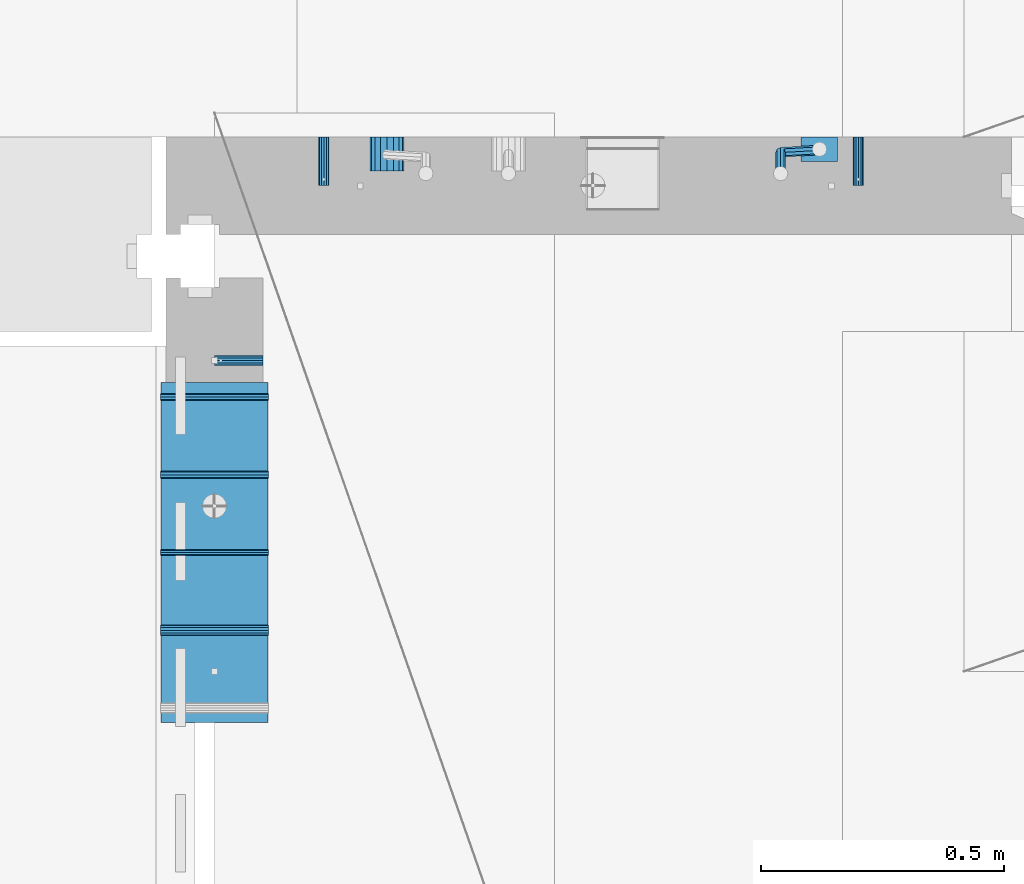
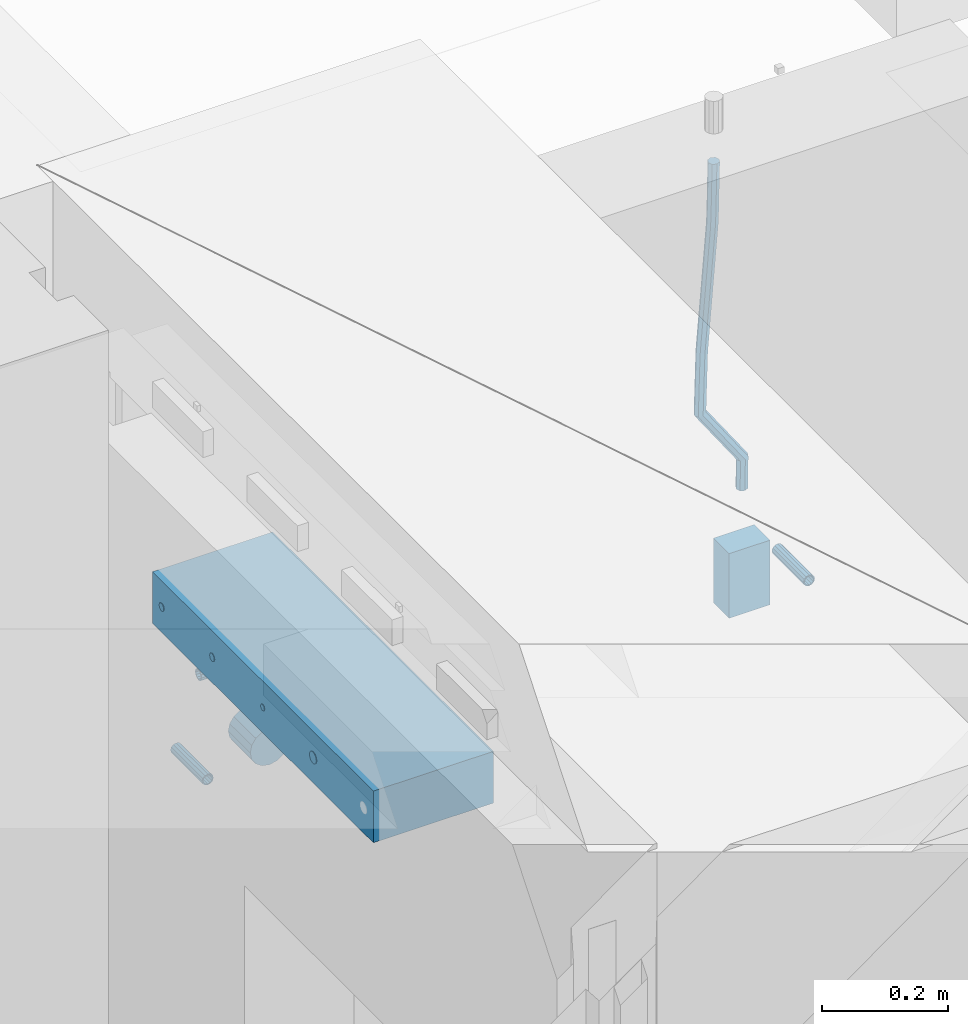
# One storey, part 164 of 350: 11 beams, 5 elements without a shape of their own.
"""IFC2X3 building model written with IfcOpenShell, lengths in millimetres."""

from ifc_helpers import new_model, si_unit, frame, origin_with_axes, place, context, subcontext, project, spatial, faceted_brep, material, type_object, element, aggregate, save


model = new_model("IFC2X3")

# Units and contexts
model_context = context("Model", 3, precision=1e-05, world=origin_with_axes())
body_context = subcontext(model_context, "Body", "Model", "MODEL_VIEW")
ifc_project = project(units=[si_unit("LENGTHUNIT", "METRE", prefix="MILLI"), si_unit("AREAUNIT", "SQUARE_METRE"), si_unit("VOLUMEUNIT", "CUBIC_METRE"), si_unit("MASSUNIT", "GRAM", prefix="KILO"), si_unit("TIMEUNIT", "SECOND"), si_unit("PLANEANGLEUNIT", "RADIAN"), si_unit("SOLIDANGLEUNIT", "STERADIAN"), si_unit("THERMODYNAMICTEMPERATUREUNIT", "DEGREE_CELSIUS"), si_unit("LUMINOUSINTENSITYUNIT", "LUMEN")], contexts=[model_context])

# Site, building, storey
site_placement = place(None, origin_with_axes())
site = spatial("IfcSite", under=ifc_project, at=site_placement, CompositionType="ELEMENT")
building_placement = place(site_placement, origin_with_axes())
building = spatial("IfcBuilding", under=site, at=building_placement, CompositionType="ELEMENT")
storey_placement = place(building_placement, origin_with_axes())
storey = spatial("IfcBuildingStorey", under=building, at=storey_placement, Name="2", CompositionType="ELEMENT", Elevation=0.0)

# Assemblies, beam
assembly_1_placement = place(storey_placement, origin_with_axes())
assembly_1 = element("IfcElementAssembly", 1, at=assembly_1_placement, inside=storey, AssemblyPlace="NOTDEFINED", PredefinedType="REINFORCEMENT_UNIT")
assembly_2_placement = place(assembly_1_placement, origin_with_axes())
assembly_2 = element("IfcElementAssembly", 2, at=assembly_2_placement, Name="Steel Assembly", AssemblyPlace="NOTDEFINED", PredefinedType="RIGID_FRAME")
ifc_material_1 = material(Name="STEEL/Steel_Undefined")
beam_type_1 = type_object("IfcBeamType", PredefinedType="NOTDEFINED")
beam_1_placement = place(assembly_2_placement, frame((26709.9991475894, 16620.0032612672, 87055.0), z_axis=(0.0, 1.0, 0.0), x_axis=(-1.0, 3.00000001838171e-08, 0.0)))
beam_1 = element("IfcBeam", 3, at=beam_1_placement, type_object=beam_type_1, material=ifc_material_1, Name="M16", context=body_context, shape_type="Brep", body=[
    faceted_brep([(0.0, -8.49999999999272, -1.45519152283669e-11), (0.0, -7.36121593215648, 4.24999999998545), (100.000000000262, -7.36121593215648, 4.24999999998545), (100.000000000262, -8.49999999999272, -1.45519152283669e-11), (0.0, -4.24999999998545, 7.36121593216376), (100.000000000262, -4.24999999998545, 7.36121593216376), (0.0, 1.45519152283669e-11, 8.49999999998545), (100.000000000262, 1.45519152283669e-11, 8.49999999998545), (0.0, 4.25000000001455, 7.36121593216376), (100.000000000262, 4.25000000001455, 7.36121593216376), (0.0, 7.36121593217104, 4.24999999998545), (100.000000000262, 7.36121593217104, 4.24999999998545), (0.0, 8.50000000000728, 0.0), (100.000000000262, 8.50000000000728, 0.0), (0.0, 7.36121593217104, -4.25000000001455), (100.000000000262, 7.36121593217104, -4.25000000001455), (0.0, 4.25000000000728, -7.36121593219286), (100.000000000262, 4.25000000000728, -7.36121593219286), (0.0, 7.27595761418343e-12, -8.5), (100.000000000262, 7.27595761418343e-12, -8.5), (0.0, -4.24999999999272, -7.36121593217831), (100.000000000262, -4.24999999999272, -7.36121593217831), (0.0, -7.36121593215648, -4.25), (100.000000000262, -7.36121593215648, -4.25), (0.0, -10.4999999999927, -1.45519152283669e-11), (0.0, -9.09326673972828, -5.25000000001455), (100.000000000262, -9.09326673972828, -5.25000000001455), (100.000000000262, -10.4999999999927, -1.45519152283669e-11), (0.0, -5.24999999998545, -9.09326673974283), (100.000000000262, -5.24999999998545, -9.09326673974283), (0.0, 7.27595761418343e-12, -10.5), (100.000000000262, 7.27595761418343e-12, -10.5), (0.0, 5.25000000001455, -9.09326673975738), (100.000000000262, 5.25000000001455, -9.09326673975738), (0.0, 9.09326673975011, -5.25000000001455), (100.000000000262, 9.09326673975011, -5.25000000001455), (0.0, 10.5000000000073, -1.45519152283669e-11), (100.000000000262, 10.5000000000073, -1.45519152283669e-11), (0.0, 9.09326673975011, 5.25), (100.000000000262, 9.09326673975011, 5.25), (0.0, 5.25000000000728, 9.09326673972828), (100.000000000262, 5.25000000000728, 9.09326673972828), (0.0, 1.45519152283669e-11, 10.4999999999854), (100.000000000262, 1.45519152283669e-11, 10.4999999999854), (0.0, -5.24999999999272, 9.09326673972828), (100.000000000262, -5.24999999999272, 9.09326673972828), (0.0, -9.09326673972828, 5.24999999998545), (100.000000000262, -9.09326673972828, 5.24999999998545)], [[[0, 1, 2, 3]], [[1, 4, 5, 2]], [[4, 6, 7, 5]], [[6, 8, 9, 7]], [[8, 10, 11, 9]], [[10, 12, 13, 11]], [[12, 14, 15, 13]], [[14, 16, 17, 15]], [[16, 18, 19, 17]], [[18, 20, 21, 19]], [[20, 22, 23, 21]], [[22, 0, 3, 23]], [[24, 25, 26, 27]], [[25, 28, 29, 26]], [[28, 30, 31, 29]], [[30, 32, 33, 31]], [[32, 34, 35, 33]], [[34, 36, 37, 35]], [[36, 38, 39, 37]], [[38, 40, 41, 39]], [[40, 42, 43, 41]], [[42, 44, 45, 43]], [[44, 46, 47, 45]], [[46, 24, 27, 47]], [[29, 31, 33, 35, 37, 39, 41, 43, 45, 47, 27, 26], [5, 7, 9, 11, 13, 15, 17, 19, 21, 23, 3, 2]], [[46, 44, 42, 40, 38, 36, 34, 32, 30, 28, 25, 24], [22, 20, 18, 16, 14, 12, 10, 8, 6, 4, 1, 0]]]),
])
aggregate(assembly_2, [beam_1])

# Assemblies, beams
assembly_3_placement = place(storey_placement, origin_with_axes())
assembly_3 = element("IfcElementAssembly", 4, at=assembly_3_placement, inside=storey, AssemblyPlace="NOTDEFINED", PredefinedType="REINFORCEMENT_UNIT")
assembly_4_placement = place(assembly_3_placement, origin_with_axes())
assembly_4 = element("IfcElementAssembly", 5, at=assembly_4_placement, Name="Steel Assembly", AssemblyPlace="NOTDEFINED", PredefinedType="RIGID_FRAME")
beam_2_placement = place(assembly_4_placement, frame((27934.9999668009, 17080.0, 86555.0), z_axis=(1.0, 0.0, 0.0), x_axis=(0.0, -1.0, 0.0)))
beam_2 = element("IfcBeam", 6, at=beam_2_placement, type_object=beam_type_1, material=ifc_material_1, Name="M16", context=body_context, shape_type="Brep", body=[
    faceted_brep([(0.0, -8.49999999999272, -1.45519152283669e-11), (0.0, -7.36121593215648, 4.24999999998545), (100.000000000262, -7.36121593215648, 4.24999999998545), (100.000000000262, -8.49999999999272, -1.45519152283669e-11), (0.0, -4.24999999998545, 7.36121593216376), (100.000000000262, -4.24999999998545, 7.36121593216376), (0.0, 1.45519152283669e-11, 8.49999999998545), (100.000000000262, 1.45519152283669e-11, 8.49999999998545), (0.0, 4.25000000001455, 7.36121593216376), (100.000000000262, 4.25000000001455, 7.36121593216376), (0.0, 7.36121593217104, 4.24999999998545), (100.000000000262, 7.36121593217104, 4.24999999998545), (0.0, 8.50000000000728, 0.0), (100.000000000262, 8.50000000000728, 0.0), (0.0, 7.36121593217104, -4.25000000001455), (100.000000000262, 7.36121593217104, -4.25000000001455), (0.0, 4.25000000000728, -7.36121593219286), (100.000000000262, 4.25000000000728, -7.36121593219286), (0.0, 7.27595761418343e-12, -8.5), (100.000000000262, 7.27595761418343e-12, -8.5), (0.0, -4.24999999999272, -7.36121593217831), (100.000000000262, -4.24999999999272, -7.36121593217831), (0.0, -7.36121593215648, -4.25), (100.000000000262, -7.36121593215648, -4.25), (0.0, -10.4999999999927, -1.45519152283669e-11), (0.0, -9.09326673972828, -5.25000000001455), (100.000000000262, -9.09326673972828, -5.25000000001455), (100.000000000262, -10.4999999999927, -1.45519152283669e-11), (0.0, -5.24999999998545, -9.09326673974283), (100.000000000262, -5.24999999998545, -9.09326673974283), (0.0, 7.27595761418343e-12, -10.5), (100.000000000262, 7.27595761418343e-12, -10.5), (0.0, 5.25000000001455, -9.09326673975738), (100.000000000262, 5.25000000001455, -9.09326673975738), (0.0, 9.09326673975011, -5.25000000001455), (100.000000000262, 9.09326673975011, -5.25000000001455), (0.0, 10.5000000000073, -1.45519152283669e-11), (100.000000000262, 10.5000000000073, -1.45519152283669e-11), (0.0, 9.09326673975011, 5.25), (100.000000000262, 9.09326673975011, 5.25), (0.0, 5.25000000000728, 9.09326673972828), (100.000000000262, 5.25000000000728, 9.09326673972828), (0.0, 1.45519152283669e-11, 10.4999999999854), (100.000000000262, 1.45519152283669e-11, 10.4999999999854), (0.0, -5.24999999999272, 9.09326673972828), (100.000000000262, -5.24999999999272, 9.09326673972828), (0.0, -9.09326673972828, 5.24999999998545), (100.000000000262, -9.09326673972828, 5.24999999998545)], [[[0, 1, 2, 3]], [[1, 4, 5, 2]], [[4, 6, 7, 5]], [[6, 8, 9, 7]], [[8, 10, 11, 9]], [[10, 12, 13, 11]], [[12, 14, 15, 13]], [[14, 16, 17, 15]], [[16, 18, 19, 17]], [[18, 20, 21, 19]], [[20, 22, 23, 21]], [[22, 0, 3, 23]], [[24, 25, 26, 27]], [[25, 28, 29, 26]], [[28, 30, 31, 29]], [[30, 32, 33, 31]], [[32, 34, 35, 33]], [[34, 36, 37, 35]], [[36, 38, 39, 37]], [[38, 40, 41, 39]], [[40, 42, 43, 41]], [[42, 44, 45, 43]], [[44, 46, 47, 45]], [[46, 24, 27, 47]], [[29, 31, 33, 35, 37, 39, 41, 43, 45, 47, 27, 26], [5, 7, 9, 11, 13, 15, 17, 19, 21, 23, 3, 2]], [[46, 44, 42, 40, 38, 36, 34, 32, 30, 28, 25, 24], [22, 20, 18, 16, 14, 12, 10, 8, 6, 4, 1, 0]]]),
])
aggregate(assembly_4, [beam_2])
assembly_5_placement = place(assembly_3_placement, origin_with_axes())
assembly_5 = element("IfcElementAssembly", 7, at=assembly_5_placement, Name="Steel Assembly", AssemblyPlace="NOTDEFINED", PredefinedType="RIGID_FRAME")
beam_3_placement = place(assembly_5_placement, frame((26834.9999668009, 17080.0, 86555.0), z_axis=(-1.0, 3.00000001838171e-08, 0.0), x_axis=(0.0, -1.0, 0.0)))
beam_3 = element("IfcBeam", 8, at=beam_3_placement, type_object=beam_type_1, material=ifc_material_1, Name="M16", context=body_context, shape_type="Brep", body=[
    faceted_brep([(0.0, -8.49999999999272, -1.45519152283669e-11), (0.0, -7.36121593215648, 4.24999999998545), (100.000000000262, -7.36121593215648, 4.24999999998545), (100.000000000262, -8.49999999999272, -1.45519152283669e-11), (0.0, -4.24999999998545, 7.36121593216376), (100.000000000262, -4.24999999998545, 7.36121593216376), (0.0, 1.45519152283669e-11, 8.49999999998545), (100.000000000262, 1.45519152283669e-11, 8.49999999998545), (0.0, 4.25000000001455, 7.36121593216376), (100.000000000262, 4.25000000001455, 7.36121593216376), (0.0, 7.36121593217104, 4.24999999998545), (100.000000000262, 7.36121593217104, 4.24999999998545), (0.0, 8.50000000000728, 0.0), (100.000000000262, 8.50000000000728, 0.0), (0.0, 7.36121593217104, -4.25000000001455), (100.000000000262, 7.36121593217104, -4.25000000001455), (0.0, 4.25000000000728, -7.36121593219286), (100.000000000262, 4.25000000000728, -7.36121593219286), (0.0, 7.27595761418343e-12, -8.5), (100.000000000262, 7.27595761418343e-12, -8.5), (0.0, -4.24999999999272, -7.36121593217831), (100.000000000262, -4.24999999999272, -7.36121593217831), (0.0, -7.36121593215648, -4.25), (100.000000000262, -7.36121593215648, -4.25), (0.0, -10.4999999999927, -1.45519152283669e-11), (0.0, -9.09326673972828, -5.25000000001455), (100.000000000262, -9.09326673972828, -5.25000000001455), (100.000000000262, -10.4999999999927, -1.45519152283669e-11), (0.0, -5.24999999998545, -9.09326673974283), (100.000000000262, -5.24999999998545, -9.09326673974283), (0.0, 7.27595761418343e-12, -10.5), (100.000000000262, 7.27595761418343e-12, -10.5), (0.0, 5.25000000001455, -9.09326673975738), (100.000000000262, 5.25000000001455, -9.09326673975738), (0.0, 9.09326673975011, -5.25000000001455), (100.000000000262, 9.09326673975011, -5.25000000001455), (0.0, 10.5000000000073, -1.45519152283669e-11), (100.000000000262, 10.5000000000073, -1.45519152283669e-11), (0.0, 9.09326673975011, 5.25), (100.000000000262, 9.09326673975011, 5.25), (0.0, 5.25000000000728, 9.09326673972828), (100.000000000262, 5.25000000000728, 9.09326673972828), (0.0, 1.45519152283669e-11, 10.4999999999854), (100.000000000262, 1.45519152283669e-11, 10.4999999999854), (0.0, -5.24999999999272, 9.09326673972828), (100.000000000262, -5.24999999999272, 9.09326673972828), (0.0, -9.09326673972828, 5.24999999998545), (100.000000000262, -9.09326673972828, 5.24999999998545)], [[[0, 1, 2, 3]], [[1, 4, 5, 2]], [[4, 6, 7, 5]], [[6, 8, 9, 7]], [[8, 10, 11, 9]], [[10, 12, 13, 11]], [[12, 14, 15, 13]], [[14, 16, 17, 15]], [[16, 18, 19, 17]], [[18, 20, 21, 19]], [[20, 22, 23, 21]], [[22, 0, 3, 23]], [[24, 25, 26, 27]], [[25, 28, 29, 26]], [[28, 30, 31, 29]], [[30, 32, 33, 31]], [[32, 34, 35, 33]], [[34, 36, 37, 35]], [[36, 38, 39, 37]], [[38, 40, 41, 39]], [[40, 42, 43, 41]], [[42, 44, 45, 43]], [[44, 46, 47, 45]], [[46, 24, 27, 47]], [[29, 31, 33, 35, 37, 39, 41, 43, 45, 47, 27, 26], [5, 7, 9, 11, 13, 15, 17, 19, 21, 23, 3, 2]], [[46, 44, 42, 40, 38, 36, 34, 32, 30, 28, 25, 24], [22, 20, 18, 16, 14, 12, 10, 8, 6, 4, 1, 0]]]),
])
aggregate(assembly_5, [beam_3])
ifc_material_2 = material()
beam_type_2 = type_object("IfcBeamType", Name="D20", PredefinedType="NOTDEFINED")
beam_4_placement = place(assembly_3_placement, frame((27854.9999105249, 17055.0000022791, 86717.5), z_axis=(0.00020576299992186, -0.999642804629538, -0.0267249099901004), x_axis=(-4.30000201928125e-08, -0.0267249099948059, 0.999642825806181)))
beam_4 = element("IfcBeam", 9, at=beam_4_placement, type_object=beam_type_2, material=ifc_material_2, Name="JM20", ObjectType="D20", context=body_context, shape_type="Brep", body=[
    faceted_brep([(0.0, -10.0, 0.0), (-4.19531716033816e-08, -7.07106781186667, -7.07106781187031), (57.3778003524785, -7.07106779628884, -7.0710678060168), (57.3778003565822, -9.99999998442945, 5.84986992180347e-09), (0.0, 0.0, -10.0), (57.3778003491898, 1.55741872731596e-08, -9.99999999415013), (4.196772351861e-08, 7.07106781186303, -7.07106781186667), (57.3778003486368, 7.07106782744086, -7.0710678060168), (0.0, 10.0, 0.0), (57.3778003511543, 10.0000000155705, 5.84986992180347e-09), (4.196772351861e-08, 7.07106781185939, 7.07106781185939), (57.3778003552725, 7.07106782744086, 7.0710678177129), (0.0, 0.0, 10.0), (57.3778003585467, 1.55741872731596e-08, 10.0000000058535), (-4.19531716033816e-08, -7.07106781187031, 7.07106781185939), (57.3778003591142, -7.07106779628884, 7.0710678177129), (63.2348501311644, -7.07106779493188, -7.07106780540926), (64.1057957623998, -9.99999998283238, 6.54472387395799e-09), (61.04994790192, 1.63490767590702e-08, -9.99999999377178), (58.8309751681372, 7.07106782761548, -7.07106780586037), (57.8777760627127, 10.0000000155014, 5.90807758271694e-09), (58.7487216939626, 7.07106782759729, 7.07106781786206), (60.9336239231925, 1.63163349498063e-08, 10.0000000062173), (63.1525966569752, -7.07106779495371, 7.07106781830953), (68.0560815638019, -3.74583294561307, -7.00896065082998), (69.6439432500047, -6.18030344188082, 0.0713424813729944), (64.0726841869619, 2.08480100043016, -9.96106107280502), (60.0271712784888, 7.89609210789058, -7.05565839484916), (58.2893494334276, 10.283864860914, 0.00530189843993867), (59.8772111196158, 7.84939436464629, 7.08560503063927), (63.8606084964704, 2.01876041860305, 10.037705452618), (67.9061214049289, -3.79253068885737, 7.13230277466573), (178.098456601496, 72.1511127806843, -5.59139360533663), (179.686318287684, 69.716642284413, 1.48890952685906), (174.115059224641, 77.9817467267239, -8.54349402731532), (170.069546316168, 83.7930378341844, -5.63809134935946), (168.331724471092, 86.1808105872078, 1.42286894392964), (169.91958615731, 83.7463400909437, 8.50317207612898), (173.90298353415, 77.9157061448968, 11.455272498104), (177.948496442623, 72.1044150374437, 8.5498698201518), (179.289255982527, 72.9724149014583, -5.57605371504542), (180.097891658399, 70.0005071298292, 1.4942114193982), (177.129995245661, 80.0611678177193, -8.50465558942597), (174.884975102759, 87.1142705605816, -5.5760589445199), (173.869297905752, 90.00011120009, 1.49420402380565), (174.67793358161, 87.0282034284573, 8.5644691582529), (176.837194318476, 79.9394505121963, 11.4930710326298), (179.082214461378, 72.8863477693376, 8.56447438772739), (180.735622590379, 72.972420835973, -5.54778204405011), (180.597796167538, 70.0005091809617, 1.50398289485383), (180.791991426609, 80.0611828430738, -8.4330757073476), (180.733882576489, 87.1142945589418, -5.46173219850607), (180.595335416292, 90.0001387973534, 1.62567575346111), (180.457508993451, 87.0282271423457, 8.67744069236505), (180.401140157206, 79.939465135245, 11.5627343556625), (180.459249007356, 72.8863534193733, 8.59139084682101), (299.223827734662, 72.9729069989553, -3.23173054285144), (299.086001311836, 70.0009953439476, 3.82003439605251), (299.280196570893, 80.0616690060597, -6.11702420615256), (299.222087720773, 87.1147807219277, -3.14568069731467), (299.083540560576, 90.0006249603393, 3.94172725465251), (298.945714137735, 87.0287133053316, 10.9934921935564), (298.889345301504, 79.9399512982272, 13.8787858568576), (298.947454151639, 72.8868395823556, 10.9074423480197), (300.386274806908, 72.9729117685347, -3.20900855728542), (299.975441269635, 70.0009989933678, 3.8374199978316), (300.554299891708, 80.0616742337661, -6.09211971118202), (300.381089708186, 87.1147854773699, -3.12302605173682), (299.968108432717, 90.0006285897653, 3.95901762330686), (299.557274895458, 87.0287158145948, 11.0054461784239), (299.389249810658, 79.9399533493597, 13.8885573323169), (299.562459994166, 72.8868421057559, 10.9194636728716), (301.54348499664, 72.972935138263, -3.09647384826167), (300.860874255726, 70.0010168745794, 3.92352530897551), (301.822663312996, 80.0616998482183, -5.96877573286474), (301.534870333402, 87.1148087778347, -3.01082485606094), (300.848691282124, 90.0006463730351, 4.04465127535514), (300.166080541225, 87.0287281093551, 11.0646504325923), (299.886902224855, 79.9399633993926, 13.9369523171918), (300.174695204449, 72.8868544697798, 10.9790014403879), (567.277632096637, 72.9783016087349, 22.7452575737989), (566.595021355723, 70.0063833450513, 29.7652567310361), (567.556810412992, 80.0670663186975, 19.8729556891958), (567.269017433413, 87.1201752483139, 22.8309065659996), (566.582838382135, 90.0060128435071, 29.886382697412), (565.900227641221, 87.0340945798234, 36.9063818546456), (565.621049324851, 79.9453298698681, 39.7786837392523), (565.90884230446, 72.8922209402554, 36.8207328624449), (567.849310941645, 72.9783131537188, 22.8008513743443), (567.441064932689, 70.0064004308078, 29.8475315576834), (568.054462827218, 80.0670763687303, 19.9213506740707), (567.93634539716, 87.1201887249226, 22.8958019142228), (567.564150240039, 90.0060326609891, 29.9818118989315), (567.155904231084, 87.0341199380709, 37.0284920822669), (566.950752345525, 79.9453567230667, 39.9079927825405), (567.068869775569, 72.8922443668707, 36.9335415423957), (568.423586898687, 72.9708243880268, 22.8084944200891), (568.290952048657, 69.9953175961527, 29.8588427157192), (568.554376054599, 80.0605573198627, 19.9280040253361), (568.606705002705, 87.1114469937784, 22.9047237384184), (568.549920154881, 89.9931778656028, 29.9949315228005), (568.417285304851, 87.0176710737251, 37.0452798184269), (568.286496148939, 79.9279381418964, 39.9257702131799), (568.234167200833, 72.8770484679771, 36.9490505000977), (589.912124239258, 72.6906061074042, 23.0944856267633), (589.779489389242, 69.7150993155265, 30.1448339223862), (590.042913395198, 79.7803390392328, 20.2139952320067), (590.095242343275, 86.8312287131521, 23.190714945089), (590.038457495451, 89.7129595849765, 30.2809227294711), (589.905822645451, 86.7374527930988, 37.3312710250975), (589.775033489525, 79.6477198612702, 40.2117614198505), (589.722704541418, 72.5968301873472, 37.2350417067682), (590.547165551296, 72.6823249395493, 23.1029373993588), (590.439554471668, 69.7064918286778, 30.1536187366546), (590.620682129796, 79.7728047264573, 20.2216847631717), (590.617039192599, 86.8244242939545, 23.197659545749), (590.538370722847, 89.7064405361089, 30.2875760807365), (590.430759643248, 86.7306074252338, 37.3382574180287), (590.357243064718, 79.6401276383258, 40.2195100542194), (590.36088600193, 72.5885080708285, 37.243535271642), (591.182260594243, 72.6841934809891, 23.1112002334121), (591.099675200006, 69.7084600799535, 30.1622167658497), (591.198500084778, 79.7744922147613, 20.2291794306657), (591.138880798317, 86.8259554442993, 23.2044030568104), (591.038326904265, 89.7079316443269, 30.2940254627501), (590.955741510043, 86.7321982432914, 37.3450419951805), (590.939502019522, 79.6418995095191, 40.2270627979342), (590.999121305984, 72.5904362799774, 37.2518391717822), (691.203058405095, 72.9824563748625, 24.4085746238379), (691.120473010888, 70.0067229738306, 31.4595911562756), (691.219297895645, 80.0727551086347, 21.5265538210951), (691.159678609169, 87.1242183381728, 24.5017774472362), (691.059124715146, 90.0061945381967, 31.591399853176), (690.976539320895, 87.0304611371721, 38.6424163856136), (690.960299830374, 79.9401624033926, 41.5244371883564), (691.019919116836, 72.8886991738545, 38.5492135622153)], [[[0, 1, 2, 3]], [[1, 4, 5, 2]], [[4, 6, 7, 5]], [[6, 8, 9, 7]], [[8, 10, 11, 9]], [[10, 12, 13, 11]], [[12, 14, 15, 13]], [[14, 0, 3, 15]], [[14, 12, 10, 8, 6, 4, 1, 0]], [[3, 2, 16, 17]], [[2, 5, 18, 16]], [[5, 7, 19, 18]], [[7, 9, 20, 19]], [[9, 11, 21, 20]], [[11, 13, 22, 21]], [[13, 15, 23, 22]], [[15, 3, 17, 23]], [[17, 16, 24, 25]], [[16, 18, 26, 24]], [[18, 19, 27, 26]], [[19, 20, 28, 27]], [[20, 21, 29, 28]], [[21, 22, 30, 29]], [[22, 23, 31, 30]], [[23, 17, 25, 31]], [[25, 24, 32, 33]], [[24, 26, 34, 32]], [[26, 27, 35, 34]], [[27, 28, 36, 35]], [[28, 29, 37, 36]], [[29, 30, 38, 37]], [[30, 31, 39, 38]], [[31, 25, 33, 39]], [[33, 32, 40, 41]], [[32, 34, 42, 40]], [[34, 35, 43, 42]], [[35, 36, 44, 43]], [[36, 37, 45, 44]], [[37, 38, 46, 45]], [[38, 39, 47, 46]], [[39, 33, 41, 47]], [[41, 40, 48, 49]], [[40, 42, 50, 48]], [[42, 43, 51, 50]], [[43, 44, 52, 51]], [[44, 45, 53, 52]], [[45, 46, 54, 53]], [[46, 47, 55, 54]], [[47, 41, 49, 55]], [[49, 48, 56, 57]], [[48, 50, 58, 56]], [[50, 51, 59, 58]], [[51, 52, 60, 59]], [[52, 53, 61, 60]], [[53, 54, 62, 61]], [[54, 55, 63, 62]], [[55, 49, 57, 63]], [[57, 56, 64, 65]], [[56, 58, 66, 64]], [[58, 59, 67, 66]], [[59, 60, 68, 67]], [[60, 61, 69, 68]], [[61, 62, 70, 69]], [[62, 63, 71, 70]], [[63, 57, 65, 71]], [[65, 64, 72, 73]], [[64, 66, 74, 72]], [[66, 67, 75, 74]], [[67, 68, 76, 75]], [[68, 69, 77, 76]], [[69, 70, 78, 77]], [[70, 71, 79, 78]], [[71, 65, 73, 79]], [[73, 72, 80, 81]], [[72, 74, 82, 80]], [[74, 75, 83, 82]], [[75, 76, 84, 83]], [[76, 77, 85, 84]], [[77, 78, 86, 85]], [[78, 79, 87, 86]], [[79, 73, 81, 87]], [[81, 80, 88, 89]], [[80, 82, 90, 88]], [[82, 83, 91, 90]], [[83, 84, 92, 91]], [[84, 85, 93, 92]], [[85, 86, 94, 93]], [[86, 87, 95, 94]], [[87, 81, 89, 95]], [[89, 88, 96, 97]], [[88, 90, 98, 96]], [[90, 91, 99, 98]], [[91, 92, 100, 99]], [[92, 93, 101, 100]], [[93, 94, 102, 101]], [[94, 95, 103, 102]], [[95, 89, 97, 103]], [[97, 96, 104, 105]], [[96, 98, 106, 104]], [[98, 99, 107, 106]], [[99, 100, 108, 107]], [[100, 101, 109, 108]], [[101, 102, 110, 109]], [[102, 103, 111, 110]], [[103, 97, 105, 111]], [[105, 104, 112, 113]], [[104, 106, 114, 112]], [[106, 107, 115, 114]], [[107, 108, 116, 115]], [[108, 109, 117, 116]], [[109, 110, 118, 117]], [[110, 111, 119, 118]], [[111, 105, 113, 119]], [[113, 112, 120, 121]], [[112, 114, 122, 120]], [[114, 115, 123, 122]], [[115, 116, 124, 123]], [[116, 117, 125, 124]], [[117, 118, 126, 125]], [[118, 119, 127, 126]], [[119, 113, 121, 127]], [[121, 120, 128, 129]], [[120, 122, 130, 128]], [[122, 123, 131, 130]], [[123, 124, 132, 131]], [[124, 125, 133, 132]], [[125, 126, 134, 133]], [[126, 127, 135, 134]], [[127, 121, 129, 135]], [[130, 131, 132, 133, 134, 135, 129, 128]]]),
])
beam_type_3 = type_object("IfcBeamType", Name="D70", PredefinedType="NOTDEFINED")
beam_5_placement = place(assembly_3_placement, frame((26964.9999105288, 17080.0000022791, 86555.0), z_axis=(0.0, 0.0, 1.0), x_axis=(0.0, -1.0, 0.0)))
beam_5 = element("IfcBeam", 10, at=beam_5_placement, type_object=beam_type_3, material=ifc_material_2, ObjectType="D70", context=body_context, shape_type="Brep", body=[
    faceted_brep([(0.0, -35.0, 0.0), (0.0, -32.3357836378964, -13.3939201327739), (70.0, -32.3357836378964, -13.3939201327739), (70.0, -35.0, 0.0), (0.0, -24.7487373415279, -24.7487373415352), (70.0, -24.7487373415279, -24.7487373415352), (0.0, -13.3939201327776, -32.3357836379), (70.0, -13.3939201327776, -32.3357836379), (0.0, 0.0, -35.0), (70.0, 0.0, -35.0), (0.0, 13.3939201327776, -32.3357836379), (70.0, 13.3939201327776, -32.3357836379), (0.0, 24.7487373415279, -24.7487373415352), (70.0, 24.7487373415279, -24.7487373415352), (0.0, 32.3357836378964, -13.3939201327739), (70.0, 32.3357836378964, -13.3939201327739), (0.0, 35.0, 0.0), (70.0, 35.0, 0.0), (0.0, 32.3357836378964, 13.3939201327739), (70.0, 32.3357836378964, 13.3939201327739), (0.0, 24.7487373415279, 24.7487373415352), (70.0, 24.7487373415279, 24.7487373415352), (0.0, 13.3939201327776, 32.3357836379), (70.0, 13.3939201327776, 32.3357836379), (0.0, 0.0, 35.0), (70.0, 0.0, 35.0), (0.0, -13.3939201327776, 32.3357836379), (70.0, -13.3939201327776, 32.3357836379), (0.0, -24.7487373415279, 24.7487373415352), (70.0, -24.7487373415279, 24.7487373415352), (0.0, -32.3357836378964, 13.3939201327739), (70.0, -32.3357836378964, 13.3939201327739)], [[[0, 1, 2, 3]], [[1, 4, 5, 2]], [[4, 6, 7, 5]], [[6, 8, 9, 7]], [[8, 10, 11, 9]], [[10, 12, 13, 11]], [[12, 14, 15, 13]], [[14, 16, 17, 15]], [[16, 18, 19, 17]], [[18, 20, 21, 19]], [[20, 22, 23, 21]], [[22, 24, 25, 23]], [[24, 26, 27, 25]], [[26, 28, 29, 27]], [[28, 30, 31, 29]], [[30, 0, 3, 31]], [[5, 7, 9, 11, 13, 15, 17, 19, 21, 23, 25, 27, 29, 31, 3, 2]], [[30, 28, 26, 24, 22, 20, 18, 16, 14, 12, 10, 8, 6, 4, 1, 0]]]),
])

# Beam
ifc_material_3 = material()
beam_type_4 = type_object("IfcBeamType", Name="D12", PredefinedType="NOTDEFINED")
beam_6_placement = place(assembly_1_placement, frame((26720.9994161083, 16225.0, 87270.0), z_axis=(0.0, -1.0, 0.0), x_axis=(-1.0, 3.00000001838171e-08, 0.0)))
beam_6 = element("IfcBeam", 11, at=beam_6_placement, type_object=beam_type_4, material=ifc_material_3, Name="12", ObjectType="D12", context=body_context, shape_type="Brep", body=[
    faceted_brep([(0.0, -6.0, -1.45519152283669e-11), (0.0, -4.24264068712, -4.24264068713819), (222.000077784061, -4.24264068712364, -4.24264068712), (222.000077784061, -6.0, 0.0), (3.63797880709171e-12, 0.0, -6.0000000000291), (222.000077784061, 0.0, -6.0), (0.0, 4.24264068712, -4.24264068713819), (222.000077784061, 4.24264068712364, -4.24264068712), (0.0, 6.0, -1.45519152283669e-11), (222.000077784061, 6.0, 0.0), (0.0, 4.24264068712, 4.24264068709454), (222.000077784061, 4.24264068712364, 4.24264068712), (0.0, 0.0, 5.99999999998545), (222.000077784061, 0.0, 6.0), (0.0, -4.24264068712, 4.24264068709454), (222.000077784061, -4.24264068712364, 4.24264068712)], [[[0, 1, 2, 3]], [[1, 4, 5, 2]], [[4, 6, 7, 5]], [[6, 8, 9, 7]], [[8, 10, 11, 9]], [[10, 12, 13, 11]], [[12, 14, 15, 13]], [[14, 0, 3, 15]], [[5, 7, 9, 11, 13, 15, 3, 2]], [[14, 12, 10, 8, 6, 4, 1, 0]]]),
])

beam_type_5 = type_object("IfcBeamType", Name="D15", PredefinedType="NOTDEFINED")
beam_7_placement = place(assembly_1_placement, frame((26720.9994161083, 16544.9998474121, 87270.0), z_axis=(0.0, -1.0, 0.0), x_axis=(-1.0, 3.00000001838171e-08, 0.0)))
beam_7 = element("IfcBeam", 12, at=beam_7_placement, type_object=beam_type_5, material=ifc_material_3, Name="15", ObjectType="D15", context=body_context, shape_type="Brep", body=[
    faceted_brep([(0.0, -7.5, 0.0), (0.0, -5.30330085889727, -5.30330085890091), (222.000077784061, -5.30330085889727, -5.30330085890091), (222.000077784061, -7.5, 0.0), (0.0, 1.45519152283669e-11, -7.5), (222.000077784061, 0.0, -7.5), (0.0, 5.30330085889727, -5.30330085890091), (222.000077784061, 5.30330085889727, -5.30330085890091), (0.0, 7.5, 0.0), (222.000077784061, 7.5, 0.0), (0.0, 5.30330085889727, 5.30330085890091), (222.000077784061, 5.30330085889727, 5.30330085890091), (0.0, 1.45519152283669e-11, 7.5), (222.000077784061, 0.0, 7.5), (0.0, -5.30330085889727, 5.30330085890091), (222.000077784061, -5.30330085889727, 5.30330085890091)], [[[0, 1, 2, 3]], [[1, 4, 5, 2]], [[4, 6, 7, 5]], [[6, 8, 9, 7]], [[8, 10, 11, 9]], [[10, 12, 13, 11]], [[12, 14, 15, 13]], [[14, 0, 3, 15]], [[5, 7, 9, 11, 13, 15, 3, 2]], [[14, 12, 10, 8, 6, 4, 1, 0]]]),
])

beam_8_placement = place(assembly_1_placement, frame((26720.9994161083, 16385.0, 87270.0), z_axis=(0.0, -1.0, 0.0), x_axis=(-1.0, 3.00000001838171e-08, 0.0)))
beam_8 = element("IfcBeam", 13, at=beam_8_placement, type_object=beam_type_5, material=ifc_material_3, Name="15", ObjectType="D15", context=body_context, shape_type="Brep", body=[
    faceted_brep([(0.0, -7.5, 0.0), (0.0, -5.30330085889727, -5.30330085890091), (222.000077784061, -5.30330085889727, -5.30330085890091), (222.000077784061, -7.5, 0.0), (0.0, 1.45519152283669e-11, -7.5), (222.000077784061, 0.0, -7.5), (0.0, 5.30330085889727, -5.30330085890091), (222.000077784061, 5.30330085889727, -5.30330085890091), (0.0, 7.5, 0.0), (222.000077784061, 7.5, 0.0), (0.0, 5.30330085889727, 5.30330085890091), (222.000077784061, 5.30330085889727, 5.30330085890091), (0.0, 1.45519152283669e-11, 7.5), (222.000077784061, 0.0, 7.5), (0.0, -5.30330085889727, 5.30330085890091), (222.000077784061, -5.30330085889727, 5.30330085890091)], [[[0, 1, 2, 3]], [[1, 4, 5, 2]], [[4, 6, 7, 5]], [[6, 8, 9, 7]], [[8, 10, 11, 9]], [[10, 12, 13, 11]], [[12, 14, 15, 13]], [[14, 0, 3, 15]], [[5, 7, 9, 11, 13, 15, 3, 2]], [[14, 12, 10, 8, 6, 4, 1, 0]]]),
])

beam_type_6 = type_object("IfcBeamType", Name="D22", PredefinedType="NOTDEFINED")
beam_9_placement = place(assembly_1_placement, frame((26720.9994161083, 16065.0, 87270.0), z_axis=(0.0, -1.0, 0.0), x_axis=(-1.0, 3.00000001838171e-08, 0.0)))
beam_9 = element("IfcBeam", 14, at=beam_9_placement, type_object=beam_type_6, material=ifc_material_3, Name="22", ObjectType="D22", context=body_context, shape_type="Brep", body=[
    faceted_brep([(0.0, -11.0, 0.0), (0.0, -9.52627944163396, -5.5), (222.000077784061, -9.52627944163396, -5.5), (222.000077784061, -11.0, 0.0), (0.0, -5.5, -9.52627944163032), (222.000077784061, -5.5, -9.52627944163032), (0.0, 0.0, -11.0), (222.000077784061, 0.0, -11.0), (0.0, 5.5, -9.52627944163032), (222.000077784061, 5.5, -9.52627944163032), (0.0, 9.52627944163396, -5.5), (222.000077784061, 9.52627944163396, -5.5), (0.0, 11.0, 0.0), (222.000077784061, 11.0, 0.0), (0.0, 9.52627944163396, 5.5), (222.000077784061, 9.52627944163396, 5.5), (0.0, 5.5, 9.52627944163032), (222.000077784061, 5.5, 9.52627944163032), (0.0, 0.0, 11.0), (222.000077784061, 0.0, 11.0), (0.0, -5.5, 9.52627944163032), (222.000077784061, -5.5, 9.52627944163032), (0.0, -9.52627944163396, 5.5), (222.000077784061, -9.52627944163396, 5.5)], [[[0, 1, 2, 3]], [[1, 4, 5, 2]], [[4, 6, 7, 5]], [[6, 8, 9, 7]], [[8, 10, 11, 9]], [[10, 12, 13, 11]], [[12, 14, 15, 13]], [[14, 16, 17, 15]], [[16, 18, 19, 17]], [[18, 20, 21, 19]], [[20, 22, 23, 21]], [[22, 0, 3, 23]], [[5, 7, 9, 11, 13, 15, 17, 19, 21, 23, 3, 2]], [[22, 20, 18, 16, 14, 12, 10, 8, 6, 4, 1, 0]]]),
])

beam_type_7 = type_object("IfcBeamType", PredefinedType="NOTDEFINED")
beam_10_placement = place(assembly_1_placement, frame((26719.9994161083, 16225.0, 87270.0), z_axis=(0.0, -1.0, 0.0), x_axis=(-1.0, 3.00000001838171e-08, 0.0)))
beam_10 = element("IfcBeam", 15, at=beam_10_placement, type_object=beam_type_7, material=ifc_material_3, context=body_context, shape_type="Brep", body=[
    faceted_brep([(0.0, 50.0, -350.0), (0.0, 50.0, 350.0), (220.000077784061, 50.0, 350.0), (220.000077784061, 50.0, -350.0), (0.0, -50.0, 350.0), (220.000077784061, -50.0, 350.0), (0.0, -50.0, -350.0), (220.000077784061, -50.0, -350.0)], [[[0, 1, 2, 3]], [[1, 4, 5, 2]], [[4, 6, 7, 5]], [[6, 0, 3, 7]], [[5, 7, 3, 2]], [[6, 4, 1, 0]]]),
])

aggregate(assembly_1, [assembly_2, beam_9, beam_6, beam_10, beam_7, beam_8])

beam_type_8 = type_object("IfcBeamType", PredefinedType="NOTDEFINED")
beam_11_placement = place(assembly_3_placement, frame((27892.4999105288, 17055.0, 86555.0), z_axis=(0.0, 0.0, 1.0), x_axis=(-1.0, 3.00000001838171e-08, 0.0)))
beam_11 = element("IfcBeam", 16, at=beam_11_placement, type_object=beam_type_8, material=ifc_material_2, Name="WM1", context=body_context, shape_type="Brep", body=[
    faceted_brep([(0.0, 25.0, -62.5), (0.0, 25.0, 62.5), (75.0, 25.0, 62.5), (75.0, 25.0, -62.5), (0.0, -25.0, 62.5), (75.0, -25.0, 62.5), (0.0, -25.0, -62.5), (75.0, -25.0, -62.5)], [[[0, 1, 2, 3]], [[1, 4, 5, 2]], [[4, 6, 7, 5]], [[6, 0, 3, 7]], [[5, 7, 3, 2]], [[0, 6, 4, 1]]]),
])

aggregate(assembly_3, [assembly_4, assembly_5, beam_4, beam_11, beam_5])

save(model, "model.ifc")
